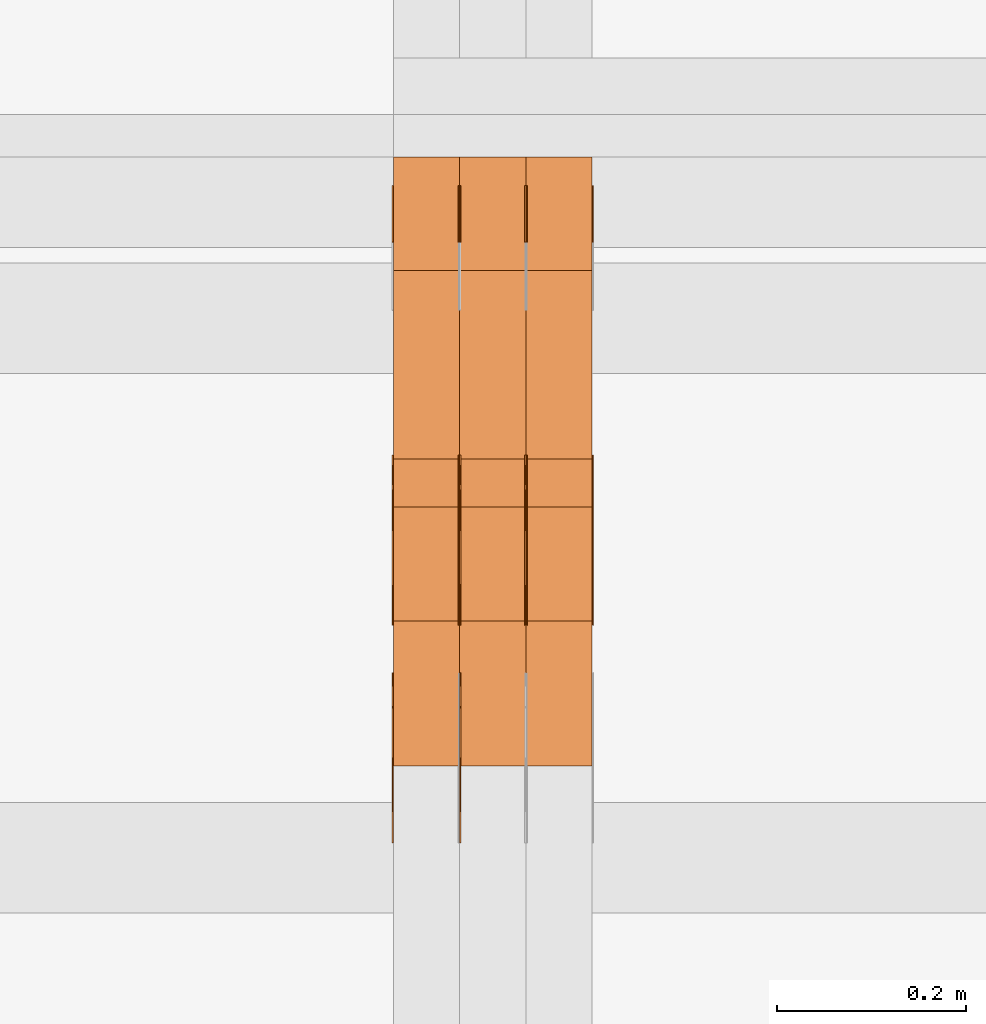
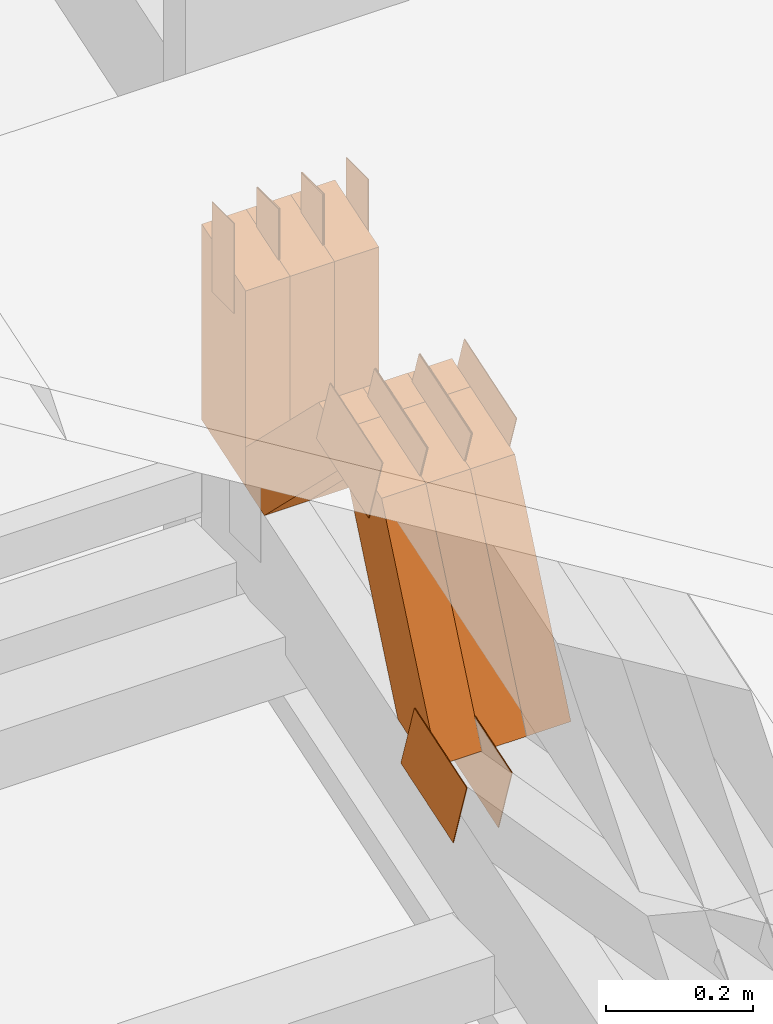
# One storey, part 81 of 385: 23 proxies.
"""IFC2X3 building model written with IfcOpenShell, lengths in millimetres."""

from ifc_helpers import new_model, entity, si_unit, converted_unit, derived_unit, direction, frame, origin, origin_2d_with_axis, place, context, subcontext, project, spatial, polyline, rectangle, outline, extrude, source, transform, mapped, material, type_object, type_shapes, element, save


model = new_model("IFC2X3")

# Units and contexts
model_context = context("Model", 3, precision=0.01, world=origin(), true_north=direction((6.12303176911189e-17, 1.0)))
body_context = subcontext(model_context, "Body", "Model", "MODEL_VIEW")
ifc_project = project(units=[si_unit("LENGTHUNIT", "METRE", prefix="MILLI"), si_unit("AREAUNIT", "SQUARE_METRE"), si_unit("VOLUMEUNIT", "CUBIC_METRE"), converted_unit("PLANEANGLEUNIT", "DEGREE", entity("IfcRatioMeasure", 0.0174532925199433), si_unit("PLANEANGLEUNIT", "RADIAN"), dimensions=[0, 0, 0, 0, 0, 0, 0]), si_unit("MASSUNIT", "GRAM", prefix="KILO"), derived_unit("MASSDENSITYUNIT", [(si_unit("MASSUNIT", "GRAM", prefix="KILO"), 1), (si_unit("LENGTHUNIT", "METRE"), -3)]), si_unit("TIMEUNIT", "SECOND"), si_unit("FREQUENCYUNIT", "HERTZ"), si_unit("THERMODYNAMICTEMPERATUREUNIT", "DEGREE_CELSIUS"), derived_unit("THERMALTRANSMITTANCEUNIT", [(si_unit("MASSUNIT", "GRAM", prefix="KILO"), 1), (si_unit("THERMODYNAMICTEMPERATUREUNIT", "KELVIN"), -1), (si_unit("TIMEUNIT", "SECOND"), -3)]), derived_unit("VOLUMETRICFLOWRATEUNIT", [(si_unit("LENGTHUNIT", "METRE"), 3), (si_unit("TIMEUNIT", "SECOND"), -1)]), si_unit("ELECTRICCURRENTUNIT", "AMPERE"), si_unit("ELECTRICVOLTAGEUNIT", "VOLT"), si_unit("POWERUNIT", "WATT"), si_unit("FORCEUNIT", "NEWTON", prefix="KILO"), si_unit("ILLUMINANCEUNIT", "LUX"), si_unit("LUMINOUSFLUXUNIT", "LUMEN"), si_unit("LUMINOUSINTENSITYUNIT", "CANDELA"), derived_unit("USERDEFINED", [(si_unit("MASSUNIT", "GRAM", prefix="KILO"), -1), (si_unit("LENGTHUNIT", "METRE"), -2), (si_unit("TIMEUNIT", "SECOND"), 3), (si_unit("LUMINOUSFLUXUNIT", "LUMEN"), 1)]), derived_unit("LINEARVELOCITYUNIT", [(si_unit("LENGTHUNIT", "METRE"), 1), (si_unit("TIMEUNIT", "SECOND"), -1)]), si_unit("PRESSUREUNIT", "PASCAL"), derived_unit("USERDEFINED", [(si_unit("LENGTHUNIT", "METRE"), -2), (si_unit("MASSUNIT", "GRAM", prefix="KILO"), 1), (si_unit("TIMEUNIT", "SECOND"), -2)])], contexts=[model_context])

# Site, building, storey
site_placement = place(None, origin())
site = spatial("IfcSite", under=ifc_project, at=site_placement, CompositionType="ELEMENT")
building_placement = place(site_placement, origin())
building = spatial("IfcBuilding", under=site, at=building_placement, CompositionType="ELEMENT")
storey_placement = place(building_placement, origin())
storey = spatial("IfcBuildingStorey", under=building, at=storey_placement, Name="Default", CompositionType="ELEMENT", Elevation=0.0)

# Proxies
ifc_material_1 = material(Name="IfcSurfaceStyle #105274")
building_element_proxy_type_1 = type_object("IfcBuildingElementProxyType", PredefinedType="NOTDEFINED", material=ifc_material_1)
shared_shape_1 = source(origin(), body_context, "Body", "SweptSolid", [
    extrude(outline(polyline([(-75.0003398116828, -59.9998507501386), (75.0003249421766, -59.9998507501386), (75.0003398116837, 59.9998507501387), (-75.0003249421775, 59.9998507501387), (-75.0003398116828, -59.9998507501386)])), frame((75.0003398116837, 60.0000773549637, 0.0), z_axis=(0.0, 0.0, 1.0), x_axis=(-1.0, 0.0, 0.0)), (0.0, 0.0, 1.0), 1.29999999999999),
])
type_shapes(building_element_proxy_type_1, [shared_shape_1])
proxy_1_placement = place(building_placement, frame((6246.29999999999, 13054.73046875, 3417.8388671875), z_axis=(-1.0, 0.0, 0.0), x_axis=(0.0, 0.951056516295124, 0.309016994375039)))
element("IfcBuildingElementProxy", 1, at=proxy_1_placement, inside=storey, type_object=building_element_proxy_type_1, material=ifc_material_1, context=body_context, shape_type="MappedRepresentation", body=[
    mapped(shared_shape_1, transform((0.0, 0.0, 0.0), scale=1.0)),
])
ifc_material_2 = material(Name="IfcSurfaceStyle #105217")
building_element_proxy_type_2 = type_object("IfcBuildingElementProxyType", PredefinedType="NOTDEFINED", material=ifc_material_2)
shared_shape_2 = source(origin(), body_context, "Body", "SweptSolid", [
    extrude(outline(polyline([(-75.0003398116828, -59.9998507501386), (75.0003249421766, -59.9998507501386), (75.0003398116837, 59.9998507501387), (-75.0003249421775, 59.9998507501387), (-75.0003398116828, -59.9998507501386)])), frame((75.0003398116837, 60.0000773549637, 0.0), z_axis=(0.0, 0.0, 1.0), x_axis=(-1.0, 0.0, 0.0)), (0.0, 0.0, 1.0), 1.29999999999999),
])
type_shapes(building_element_proxy_type_2, [shared_shape_2])
proxy_2_placement = place(building_placement, frame((6175.0, 13054.73046875, 3417.8388671875), z_axis=(-1.0, 0.0, 0.0), x_axis=(0.0, 0.951056516295124, 0.309016994375039)))
element("IfcBuildingElementProxy", 2, at=proxy_2_placement, inside=storey, type_object=building_element_proxy_type_2, material=ifc_material_2, context=body_context, shape_type="MappedRepresentation", body=[
    mapped(shared_shape_2, transform((0.0, 0.0, 0.0), scale=1.0)),
])
ifc_material_3 = material(Name="IfcSurfaceStyle #97636")
building_element_proxy_type_3 = type_object("IfcBuildingElementProxyType", PredefinedType="NOTDEFINED", material=ifc_material_3)
shared_shape_3 = source(origin(), body_context, "Body", "SweptSolid", [
    extrude(outline(polyline([(-74.999875428623, -60.0000016373506), (74.9998605591059, -60.0000016373506), (74.9998754286239, 60.0000016373506), (-74.9998605591068, 60.0000016373506), (-74.999875428623, -60.0000016373506)])), frame((75.0002691827262, 60.0000190504561, 0.0), z_axis=(0.0, 0.0, 1.0), x_axis=(-1.0, 0.0, 0.0)), (0.0, 0.0, 1.0), 1.3),
])
type_shapes(building_element_proxy_type_3, [shared_shape_3])
proxy_3_placement = place(building_placement, frame((6386.29999999999, 13285.0865109705, 3819.37496637467), z_axis=(-1.0, 0.0, 0.0), x_axis=(0.0, 0.951056516295154, 0.309016994374948)))
element("IfcBuildingElementProxy", 3, at=proxy_3_placement, inside=storey, type_object=building_element_proxy_type_3, material=ifc_material_3, context=body_context, shape_type="MappedRepresentation", body=[
    mapped(shared_shape_3, transform((0.0, 0.0, 0.0), scale=1.0)),
])
ifc_material_4 = material(Name="IfcSurfaceStyle #97579")
building_element_proxy_type_4 = type_object("IfcBuildingElementProxyType", PredefinedType="NOTDEFINED", material=ifc_material_4)
shared_shape_4 = source(origin(), body_context, "Body", "SweptSolid", [
    extrude(outline(polyline([(-74.999875428623, -60.0000016373506), (74.9998605591059, -60.0000016373506), (74.9998754286239, 60.0000016373506), (-74.9998605591068, 60.0000016373506), (-74.999875428623, -60.0000016373506)])), frame((75.0002691827262, 60.0000190504561, 0.0), z_axis=(0.0, 0.0, 1.0), x_axis=(-1.0, 0.0, 0.0)), (0.0, 0.0, 1.0), 1.3),
])
type_shapes(building_element_proxy_type_4, [shared_shape_4])
proxy_4_placement = place(building_placement, frame((6315.0, 13285.0865109705, 3819.37496637467), z_axis=(-1.0, 0.0, 0.0), x_axis=(0.0, 0.951056516295154, 0.309016994374948)))
element("IfcBuildingElementProxy", 4, at=proxy_4_placement, inside=storey, type_object=building_element_proxy_type_4, material=ifc_material_4, context=body_context, shape_type="MappedRepresentation", body=[
    mapped(shared_shape_4, transform((0.0, 0.0, 0.0), scale=1.0)),
])
ifc_material_5 = material(Name="IfcSurfaceStyle #97522")
building_element_proxy_type_5 = type_object("IfcBuildingElementProxyType", PredefinedType="NOTDEFINED", material=ifc_material_5)
shared_shape_5 = source(origin(), body_context, "Body", "SweptSolid", [
    extrude(outline(polyline([(-74.999875428623, -60.0000016373506), (74.9998605591059, -60.0000016373506), (74.9998754286239, 60.0000016373506), (-74.9998605591068, 60.0000016373506), (-74.999875428623, -60.0000016373506)])), frame((75.0002691827262, 60.0000190504561, 0.0), z_axis=(0.0, 0.0, 1.0), x_axis=(-1.0, 0.0, 0.0)), (0.0, 0.0, 1.0), 1.3),
])
type_shapes(building_element_proxy_type_5, [shared_shape_5])
proxy_5_placement = place(building_placement, frame((6316.29999999999, 13285.0865109705, 3819.37496637467), z_axis=(-1.0, 0.0, 0.0), x_axis=(0.0, 0.951056516295154, 0.309016994374948)))
element("IfcBuildingElementProxy", 5, at=proxy_5_placement, inside=storey, type_object=building_element_proxy_type_5, material=ifc_material_5, context=body_context, shape_type="MappedRepresentation", body=[
    mapped(shared_shape_5, transform((0.0, 0.0, 0.0), scale=1.0)),
])
ifc_material_6 = material(Name="IfcSurfaceStyle #97465")
building_element_proxy_type_6 = type_object("IfcBuildingElementProxyType", PredefinedType="NOTDEFINED", material=ifc_material_6)
shared_shape_6 = source(origin(), body_context, "Body", "SweptSolid", [
    extrude(outline(polyline([(-74.999875428623, -60.0000016373506), (74.9998605591059, -60.0000016373506), (74.9998754286239, 60.0000016373506), (-74.9998605591068, 60.0000016373506), (-74.999875428623, -60.0000016373506)])), frame((75.0002691827262, 60.0000190504561, 0.0), z_axis=(0.0, 0.0, 1.0), x_axis=(-1.0, 0.0, 0.0)), (0.0, 0.0, 1.0), 1.29999999999999),
])
type_shapes(building_element_proxy_type_6, [shared_shape_6])
proxy_6_placement = place(building_placement, frame((6245.0, 13285.0865109705, 3819.37496637467), z_axis=(-1.0, 0.0, 0.0), x_axis=(0.0, 0.951056516295154, 0.309016994374948)))
element("IfcBuildingElementProxy", 6, at=proxy_6_placement, inside=storey, type_object=building_element_proxy_type_6, material=ifc_material_6, context=body_context, shape_type="MappedRepresentation", body=[
    mapped(shared_shape_6, transform((0.0, 0.0, 0.0), scale=1.0)),
])
ifc_material_7 = material(Name="IfcSurfaceStyle #97408")
building_element_proxy_type_7 = type_object("IfcBuildingElementProxyType", PredefinedType="NOTDEFINED", material=ifc_material_7)
shared_shape_7 = source(origin(), body_context, "Body", "SweptSolid", [
    extrude(outline(polyline([(-74.999875428623, -60.0000016373506), (74.9998605591059, -60.0000016373506), (74.9998754286239, 60.0000016373506), (-74.9998605591068, 60.0000016373506), (-74.999875428623, -60.0000016373506)])), frame((75.0002691827262, 60.0000190504561, 0.0), z_axis=(0.0, 0.0, 1.0), x_axis=(-1.0, 0.0, 0.0)), (0.0, 0.0, 1.0), 1.29999999999999),
])
type_shapes(building_element_proxy_type_7, [shared_shape_7])
proxy_7_placement = place(building_placement, frame((6246.29999999999, 13285.0865109705, 3819.37496637467), z_axis=(-1.0, 0.0, 0.0), x_axis=(0.0, 0.951056516295154, 0.309016994374948)))
element("IfcBuildingElementProxy", 7, at=proxy_7_placement, inside=storey, type_object=building_element_proxy_type_7, material=ifc_material_7, context=body_context, shape_type="MappedRepresentation", body=[
    mapped(shared_shape_7, transform((0.0, 0.0, 0.0), scale=1.0)),
])
ifc_material_8 = material(Name="IfcSurfaceStyle #97351")
building_element_proxy_type_8 = type_object("IfcBuildingElementProxyType", PredefinedType="NOTDEFINED", material=ifc_material_8)
shared_shape_8 = source(origin(), body_context, "Body", "SweptSolid", [
    extrude(outline(polyline([(-74.999875428623, -60.0000016373506), (74.9998605591059, -60.0000016373506), (74.9998754286239, 60.0000016373506), (-74.9998605591068, 60.0000016373506), (-74.999875428623, -60.0000016373506)])), frame((75.0002691827262, 60.0000190504561, 0.0), z_axis=(0.0, 0.0, 1.0), x_axis=(-1.0, 0.0, 0.0)), (0.0, 0.0, 1.0), 1.29999999999999),
])
type_shapes(building_element_proxy_type_8, [shared_shape_8])
proxy_8_placement = place(building_placement, frame((6175.0, 13285.0865109705, 3819.37496637467), z_axis=(-1.0, 0.0, 0.0), x_axis=(0.0, 0.951056516295154, 0.309016994374948)))
element("IfcBuildingElementProxy", 8, at=proxy_8_placement, inside=storey, type_object=building_element_proxy_type_8, material=ifc_material_8, context=body_context, shape_type="MappedRepresentation", body=[
    mapped(shared_shape_8, transform((0.0, 0.0, 0.0), scale=1.0)),
])
ifc_material_9 = material(Name="IfcSurfaceStyle #96952")
building_element_proxy_type_9 = type_object("IfcBuildingElementProxyType", PredefinedType="NOTDEFINED", material=ifc_material_9)
shared_shape_9 = source(origin(), body_context, "Body", "SweptSolid", [
    extrude(rectangle(XDim=150.0, YDim=60.0, at=origin_2d_with_axis()), frame((75.0000705696166, 30.0, 0.0), z_axis=(0.0, 0.0, 1.0), x_axis=(-1.0, 0.0, 0.0)), (0.0, 0.0, 1.0), 1.3),
])
type_shapes(building_element_proxy_type_9, [shared_shape_9])
proxy_9_placement = place(building_placement, frame((6386.29999999999, 13750.0, 3972.59919166337), z_axis=(-1.0, 0.0, 0.0), x_axis=(0.0, 0.0, -1.0)))
element("IfcBuildingElementProxy", 9, at=proxy_9_placement, inside=storey, type_object=building_element_proxy_type_9, material=ifc_material_9, context=body_context, shape_type="MappedRepresentation", body=[
    mapped(shared_shape_9, transform((0.0, 0.0, 0.0), scale=1.0)),
])
ifc_material_10 = material(Name="IfcSurfaceStyle #96895")
building_element_proxy_type_10 = type_object("IfcBuildingElementProxyType", PredefinedType="NOTDEFINED", material=ifc_material_10)
shared_shape_10 = source(origin(), body_context, "Body", "SweptSolid", [
    extrude(rectangle(XDim=150.0, YDim=60.0, at=origin_2d_with_axis()), frame((75.0000705696166, 30.0, 0.0), z_axis=(0.0, 0.0, 1.0), x_axis=(-1.0, 0.0, 0.0)), (0.0, 0.0, 1.0), 1.3),
])
type_shapes(building_element_proxy_type_10, [shared_shape_10])
proxy_10_placement = place(building_placement, frame((6315.0, 13750.0, 3972.59919166337), z_axis=(-1.0, 0.0, 0.0), x_axis=(0.0, 0.0, -1.0)))
element("IfcBuildingElementProxy", 10, at=proxy_10_placement, inside=storey, type_object=building_element_proxy_type_10, material=ifc_material_10, context=body_context, shape_type="MappedRepresentation", body=[
    mapped(shared_shape_10, transform((0.0, 0.0, 0.0), scale=1.0)),
])
ifc_material_11 = material(Name="IfcSurfaceStyle #96838")
building_element_proxy_type_11 = type_object("IfcBuildingElementProxyType", PredefinedType="NOTDEFINED", material=ifc_material_11)
shared_shape_11 = source(origin(), body_context, "Body", "SweptSolid", [
    extrude(rectangle(XDim=150.0, YDim=60.0, at=origin_2d_with_axis()), frame((75.0000705696166, 30.0, 0.0), z_axis=(0.0, 0.0, 1.0), x_axis=(-1.0, 0.0, 0.0)), (0.0, 0.0, 1.0), 1.3),
])
type_shapes(building_element_proxy_type_11, [shared_shape_11])
proxy_11_placement = place(building_placement, frame((6316.29999999999, 13750.0, 3972.59919166337), z_axis=(-1.0, 0.0, 0.0), x_axis=(0.0, 0.0, -1.0)))
element("IfcBuildingElementProxy", 11, at=proxy_11_placement, inside=storey, type_object=building_element_proxy_type_11, material=ifc_material_11, context=body_context, shape_type="MappedRepresentation", body=[
    mapped(shared_shape_11, transform((0.0, 0.0, 0.0), scale=1.0)),
])
ifc_material_12 = material(Name="IfcSurfaceStyle #96781")
building_element_proxy_type_12 = type_object("IfcBuildingElementProxyType", PredefinedType="NOTDEFINED", material=ifc_material_12)
shared_shape_12 = source(origin(), body_context, "Body", "SweptSolid", [
    extrude(rectangle(XDim=150.0, YDim=60.0, at=origin_2d_with_axis()), frame((75.0000705696166, 30.0, 0.0), z_axis=(0.0, 0.0, 1.0), x_axis=(-1.0, 0.0, 0.0)), (0.0, 0.0, 1.0), 1.29999999999999),
])
type_shapes(building_element_proxy_type_12, [shared_shape_12])
proxy_12_placement = place(building_placement, frame((6245.0, 13750.0, 3972.59919166337), z_axis=(-1.0, 0.0, 0.0), x_axis=(0.0, 0.0, -1.0)))
element("IfcBuildingElementProxy", 12, at=proxy_12_placement, inside=storey, type_object=building_element_proxy_type_12, material=ifc_material_12, context=body_context, shape_type="MappedRepresentation", body=[
    mapped(shared_shape_12, transform((0.0, 0.0, 0.0), scale=1.0)),
])
ifc_material_13 = material(Name="IfcSurfaceStyle #96724")
building_element_proxy_type_13 = type_object("IfcBuildingElementProxyType", PredefinedType="NOTDEFINED", material=ifc_material_13)
shared_shape_13 = source(origin(), body_context, "Body", "SweptSolid", [
    extrude(rectangle(XDim=150.0, YDim=60.0, at=origin_2d_with_axis()), frame((75.0000705696166, 30.0, 0.0), z_axis=(0.0, 0.0, 1.0), x_axis=(-1.0, 0.0, 0.0)), (0.0, 0.0, 1.0), 1.29999999999999),
])
type_shapes(building_element_proxy_type_13, [shared_shape_13])
proxy_13_placement = place(building_placement, frame((6246.29999999999, 13750.0, 3972.59919166337), z_axis=(-1.0, 0.0, 0.0), x_axis=(0.0, 0.0, -1.0)))
element("IfcBuildingElementProxy", 13, at=proxy_13_placement, inside=storey, type_object=building_element_proxy_type_13, material=ifc_material_13, context=body_context, shape_type="MappedRepresentation", body=[
    mapped(shared_shape_13, transform((0.0, 0.0, 0.0), scale=1.0)),
])
ifc_material_14 = material(Name="IfcSurfaceStyle #96667")
building_element_proxy_type_14 = type_object("IfcBuildingElementProxyType", PredefinedType="NOTDEFINED", material=ifc_material_14)
shared_shape_14 = source(origin(), body_context, "Body", "SweptSolid", [
    extrude(rectangle(XDim=150.0, YDim=60.0, at=origin_2d_with_axis()), frame((75.0000705696166, 30.0, 0.0), z_axis=(0.0, 0.0, 1.0), x_axis=(-1.0, 0.0, 0.0)), (0.0, 0.0, 1.0), 1.29999999999999),
])
type_shapes(building_element_proxy_type_14, [shared_shape_14])
proxy_14_placement = place(building_placement, frame((6175.0, 13750.0, 3972.59919166337), z_axis=(-1.0, 0.0, 0.0), x_axis=(0.0, 0.0, -1.0)))
element("IfcBuildingElementProxy", 14, at=proxy_14_placement, inside=storey, type_object=building_element_proxy_type_14, material=ifc_material_14, context=body_context, shape_type="MappedRepresentation", body=[
    mapped(shared_shape_14, transform((0.0, 0.0, 0.0), scale=1.0)),
])
ifc_material_15 = material(Name="IfcSurfaceStyle #87466")
building_element_proxy_type_15 = type_object("IfcBuildingElementProxyType", Name="T1-W49 87464", PredefinedType="NOTDEFINED", material=ifc_material_15)
shared_shape_15 = source(origin(), body_context, "Body", "SweptSolid", [
    extrude(outline(polyline([(-155.175867306415, -47.4997478409253), (152.310664695054, -47.4997478409253), (170.496756790954, -6.14570120142345e-05), (145.70957993751, 47.4998092979374), (-133.37808995724, 47.4998092979373), (-179.963044159863, -6.14570120298391e-05), (-155.175867306415, -47.4997478409253)])), frame((170.496756790954, 47.5001152140455, 0.0), z_axis=(0.0, 0.0, 1.0), x_axis=(-1.0, 0.0, 0.0)), (0.0, 0.0, 1.0), 70.0),
])
type_shapes(building_element_proxy_type_15, [shared_shape_15])
proxy_15_placement = place(building_placement, frame((6385.0, 13443.048524104, 3830.71841973934), z_axis=(-1.0, 0.0, 0.0), x_axis=(0.0, 0.713950095632063, -0.700196587357413)))
element("IfcBuildingElementProxy", 15, at=proxy_15_placement, inside=storey, type_object=building_element_proxy_type_15, material=ifc_material_15, Name="T1-W49", context=body_context, shape_type="MappedRepresentation", body=[
    mapped(shared_shape_15, transform((0.0, 0.0, 0.0), scale=1.0)),
])
ifc_material_16 = material(Name="IfcSurfaceStyle #87391")
building_element_proxy_type_16 = type_object("IfcBuildingElementProxyType", Name="T1-W49 87389", PredefinedType="NOTDEFINED", material=ifc_material_16)
shared_shape_16 = source(origin(), body_context, "Body", "SweptSolid", [
    extrude(outline(polyline([(-155.175867306415, -47.4997478409253), (152.310664695054, -47.4997478409253), (170.496756790954, -6.14570120142345e-05), (145.70957993751, 47.4998092979374), (-133.37808995724, 47.4998092979373), (-179.963044159863, -6.14570120298391e-05), (-155.175867306415, -47.4997478409253)])), frame((170.496756790954, 47.5001152140455, 0.0), z_axis=(0.0, 0.0, 1.0), x_axis=(-1.0, 0.0, 0.0)), (0.0, 0.0, 1.0), 70.0),
])
type_shapes(building_element_proxy_type_16, [shared_shape_16])
proxy_16_placement = place(building_placement, frame((6315.0, 13443.048524104, 3830.71841973934), z_axis=(-1.0, 0.0, 0.0), x_axis=(0.0, 0.713950095632063, -0.700196587357413)))
element("IfcBuildingElementProxy", 16, at=proxy_16_placement, inside=storey, type_object=building_element_proxy_type_16, material=ifc_material_16, Name="T1-W49", context=body_context, shape_type="MappedRepresentation", body=[
    mapped(shared_shape_16, transform((0.0, 0.0, 0.0), scale=1.0)),
])
ifc_material_17 = material(Name="IfcSurfaceStyle #87316")
building_element_proxy_type_17 = type_object("IfcBuildingElementProxyType", Name="T1-W49 87314", PredefinedType="NOTDEFINED", material=ifc_material_17)
shared_shape_17 = source(origin(), body_context, "Body", "SweptSolid", [
    extrude(outline(polyline([(-155.175867306415, -47.4997478409253), (152.310664695054, -47.4997478409253), (170.496756790954, -6.14570120142345e-05), (145.70957993751, 47.4998092979374), (-133.37808995724, 47.4998092979373), (-179.963044159863, -6.14570120298391e-05), (-155.175867306415, -47.4997478409253)])), frame((170.496756790954, 47.5001152140455, 0.0), z_axis=(0.0, 0.0, 1.0), x_axis=(-1.0, 0.0, 0.0)), (0.0, 0.0, 1.0), 70.0),
])
type_shapes(building_element_proxy_type_17, [shared_shape_17])
proxy_17_placement = place(building_placement, frame((6245.0, 13443.048524104, 3830.71841973934), z_axis=(-1.0, 0.0, 0.0), x_axis=(0.0, 0.713950095632063, -0.700196587357413)))
element("IfcBuildingElementProxy", 17, at=proxy_17_placement, inside=storey, type_object=building_element_proxy_type_17, material=ifc_material_17, Name="T1-W49", context=body_context, shape_type="MappedRepresentation", body=[
    mapped(shared_shape_17, transform((0.0, 0.0, 0.0), scale=1.0)),
])
ifc_material_18 = material(Name="IfcSurfaceStyle #87016")
building_element_proxy_type_18 = type_object("IfcBuildingElementProxyType", Name="T1-W1 87014", PredefinedType="NOTDEFINED", material=ifc_material_18)
shared_shape_18 = source(origin(), body_context, "Body", "SweptSolid", [
    extrude(outline(polyline([(-182.839782714844, -60.0), (143.849426269531, -60.0), (182.839660644531, 60.0), (-143.849304199219, 60.0), (-182.839782714844, -60.0)])), frame((182.839674685549, 60.0, 0.0), z_axis=(0.0, 0.0, 1.0), x_axis=(-1.0, 0.0, 0.0)), (0.0, 0.0, 1.0), 70.0),
])
type_shapes(building_element_proxy_type_18, [shared_shape_18])
proxy_18_placement = place(building_placement, frame((6385.0, 13660.0, 3551.41502502148), z_axis=(-1.0, 0.0, 0.0), x_axis=(0.0, 0.0, 1.0)))
element("IfcBuildingElementProxy", 18, at=proxy_18_placement, inside=storey, type_object=building_element_proxy_type_18, material=ifc_material_18, Name="T1-W1", context=body_context, shape_type="MappedRepresentation", body=[
    mapped(shared_shape_18, transform((0.0, 0.0, 0.0), scale=1.0)),
])
ifc_material_19 = material(Name="IfcSurfaceStyle #86959")
building_element_proxy_type_19 = type_object("IfcBuildingElementProxyType", Name="T1-W1 86957", PredefinedType="NOTDEFINED", material=ifc_material_19)
shared_shape_19 = source(origin(), body_context, "Body", "SweptSolid", [
    extrude(outline(polyline([(-182.839782714844, -60.0), (143.849426269531, -60.0), (182.839660644531, 60.0), (-143.849304199219, 60.0), (-182.839782714844, -60.0)])), frame((182.839674685549, 60.0, 0.0), z_axis=(0.0, 0.0, 1.0), x_axis=(-1.0, 0.0, 0.0)), (0.0, 0.0, 1.0), 70.0),
])
type_shapes(building_element_proxy_type_19, [shared_shape_19])
proxy_19_placement = place(building_placement, frame((6315.0, 13660.0, 3551.41502502148), z_axis=(-1.0, 0.0, 0.0), x_axis=(0.0, 0.0, 1.0)))
element("IfcBuildingElementProxy", 19, at=proxy_19_placement, inside=storey, type_object=building_element_proxy_type_19, material=ifc_material_19, Name="T1-W1", context=body_context, shape_type="MappedRepresentation", body=[
    mapped(shared_shape_19, transform((0.0, 0.0, 0.0), scale=1.0)),
])
ifc_material_20 = material(Name="IfcSurfaceStyle #86902")
building_element_proxy_type_20 = type_object("IfcBuildingElementProxyType", Name="T1-W1 86900", PredefinedType="NOTDEFINED", material=ifc_material_20)
shared_shape_20 = source(origin(), body_context, "Body", "SweptSolid", [
    extrude(outline(polyline([(-182.839782714844, -60.0), (143.849426269531, -60.0), (182.839660644531, 60.0), (-143.849304199219, 60.0), (-182.839782714844, -60.0)])), frame((182.839674685549, 60.0, 0.0), z_axis=(0.0, 0.0, 1.0), x_axis=(-1.0, 0.0, 0.0)), (0.0, 0.0, 1.0), 70.0),
])
type_shapes(building_element_proxy_type_20, [shared_shape_20])
proxy_20_placement = place(building_placement, frame((6245.0, 13660.0, 3551.41502502148), z_axis=(-1.0, 0.0, 0.0), x_axis=(0.0, 0.0, 1.0)))
element("IfcBuildingElementProxy", 20, at=proxy_20_placement, inside=storey, type_object=building_element_proxy_type_20, material=ifc_material_20, Name="T1-W1", context=body_context, shape_type="MappedRepresentation", body=[
    mapped(shared_shape_20, transform((0.0, 0.0, 0.0), scale=1.0)),
])
ifc_material_21 = material(Name="IfcSurfaceStyle #86476")
building_element_proxy_type_21 = type_object("IfcBuildingElementProxyType", Name="T1-W42 86474", PredefinedType="NOTDEFINED", material=ifc_material_21)
shared_shape_21 = source(origin(), body_context, "Body", "SweptSolid", [
    extrude(outline(polyline([(-284.837590197601, -47.4997543607933), (129.95880168156, -47.4997543607933), (171.972324990451, 0.000162623346093338), (183.717007105413, 47.4996730491203), (-200.810543579822, 47.4996730491203), (-284.837590197601, -47.4997543607933)])), frame((183.717155718752, 47.4999821655365, 0.0), z_axis=(0.0, 0.0, 1.0), x_axis=(-1.0, 0.0, 0.0)), (0.0, 0.0, 1.0), 70.0),
])
type_shapes(building_element_proxy_type_21, [shared_shape_21])
proxy_21_placement = place(building_placement, frame((6385.0, 13135.8834463264, 3404.958483022), z_axis=(-1.0, 0.0, 0.0), x_axis=(0.0, 0.398630596470292, 0.917111578575769)))
element("IfcBuildingElementProxy", 21, at=proxy_21_placement, inside=storey, type_object=building_element_proxy_type_21, material=ifc_material_21, Name="T1-W42", context=body_context, shape_type="MappedRepresentation", body=[
    mapped(shared_shape_21, transform((0.0, 0.0, 0.0), scale=1.0)),
])
ifc_material_22 = material(Name="IfcSurfaceStyle #86410")
building_element_proxy_type_22 = type_object("IfcBuildingElementProxyType", Name="T1-W42 86408", PredefinedType="NOTDEFINED", material=ifc_material_22)
shared_shape_22 = source(origin(), body_context, "Body", "SweptSolid", [
    extrude(outline(polyline([(-284.837590197601, -47.4997543607933), (129.95880168156, -47.4997543607933), (171.972324990451, 0.000162623346093338), (183.717007105413, 47.4996730491203), (-200.810543579822, 47.4996730491203), (-284.837590197601, -47.4997543607933)])), frame((183.717155718752, 47.4999821655365, 0.0), z_axis=(0.0, 0.0, 1.0), x_axis=(-1.0, 0.0, 0.0)), (0.0, 0.0, 1.0), 70.0),
])
type_shapes(building_element_proxy_type_22, [shared_shape_22])
proxy_22_placement = place(building_placement, frame((6315.0, 13135.8834463264, 3404.958483022), z_axis=(-1.0, 0.0, 0.0), x_axis=(0.0, 0.398630596470292, 0.917111578575769)))
element("IfcBuildingElementProxy", 22, at=proxy_22_placement, inside=storey, type_object=building_element_proxy_type_22, material=ifc_material_22, Name="T1-W42", context=body_context, shape_type="MappedRepresentation", body=[
    mapped(shared_shape_22, transform((0.0, 0.0, 0.0), scale=1.0)),
])
ifc_material_23 = material(Name="IfcSurfaceStyle #86344")
building_element_proxy_type_23 = type_object("IfcBuildingElementProxyType", Name="T1-W42 86342", PredefinedType="NOTDEFINED", material=ifc_material_23)
shared_shape_23 = source(origin(), body_context, "Body", "SweptSolid", [
    extrude(outline(polyline([(-284.837590197601, -47.4997543607933), (129.95880168156, -47.4997543607933), (171.972324990451, 0.000162623346093338), (183.717007105413, 47.4996730491203), (-200.810543579822, 47.4996730491203), (-284.837590197601, -47.4997543607933)])), frame((183.717155718752, 47.4999821655365, 0.0), z_axis=(0.0, 0.0, 1.0), x_axis=(-1.0, 0.0, 0.0)), (0.0, 0.0, 1.0), 70.0),
])
type_shapes(building_element_proxy_type_23, [shared_shape_23])
proxy_23_placement = place(building_placement, frame((6245.0, 13135.8834463264, 3404.958483022), z_axis=(-1.0, 0.0, 0.0), x_axis=(0.0, 0.398630596470292, 0.917111578575769)))
element("IfcBuildingElementProxy", 23, at=proxy_23_placement, inside=storey, type_object=building_element_proxy_type_23, material=ifc_material_23, Name="T1-W42", context=body_context, shape_type="MappedRepresentation", body=[
    mapped(shared_shape_23, transform((0.0, 0.0, 0.0), scale=1.0)),
])

save(model, "model.ifc")
